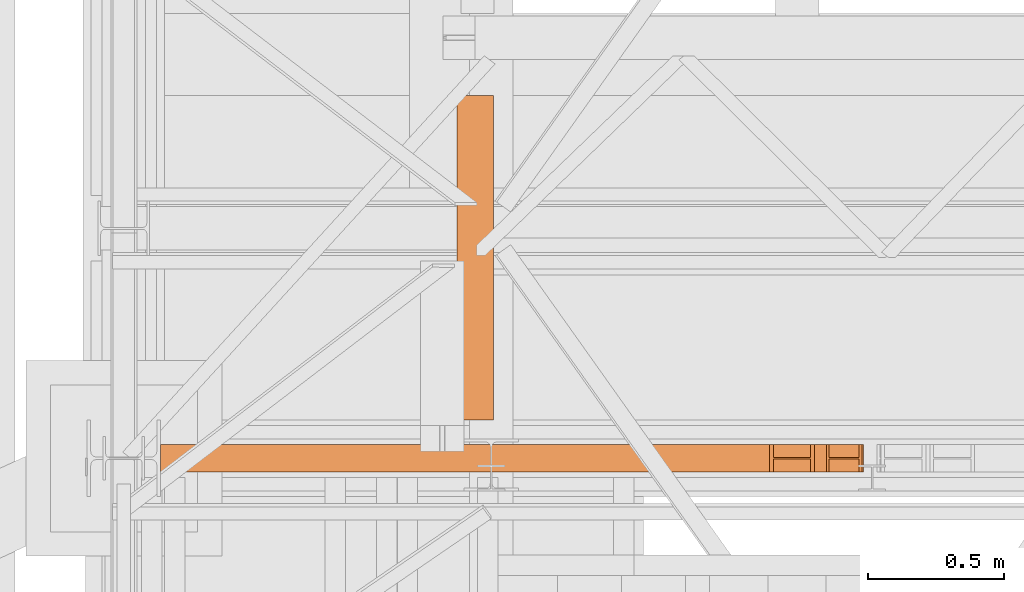
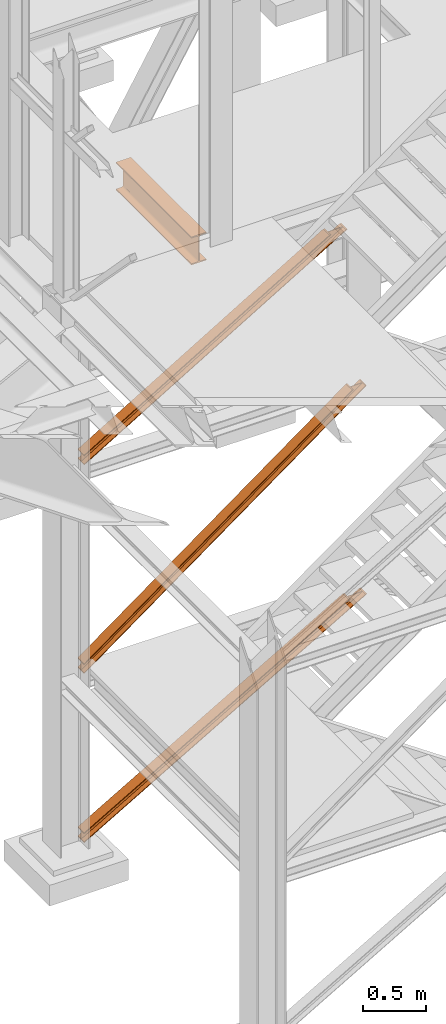
# One storey, part 15 of 208: 4 proxies.
"""IFC2X3 building model written with IfcOpenShell, lengths in millimetres."""

from ifc_helpers import new_model, entity, si_unit, converted_unit, frame, origin, origin_with_axes, place, context, subcontext, project, spatial, faceted_brep, element, save


model = new_model("IFC2X3")

# Units and contexts
model_context = context("Model", 3, precision=1e-05, world=origin())
plan_context = context("Plan", 3, precision=1e-05, world=origin())
body_context = subcontext(model_context, "Body", "Model", "MODEL_VIEW")
ifc_project = project(units=[si_unit("LENGTHUNIT", "METRE", prefix="MILLI"), converted_unit("PLANEANGLEUNIT", "DEGREE", entity("IfcPlaneAngleMeasure", 0.0174532925199433), si_unit("PLANEANGLEUNIT", "RADIAN"), dimensions=[0, 0, 0, 0, 0, 0, 0]), si_unit("AREAUNIT", "SQUARE_METRE"), si_unit("VOLUMEUNIT", "CUBIC_METRE")], contexts=[model_context, plan_context])

# Building, storey
building_placement = place(None, origin())
building = spatial("IfcBuilding", under=ifc_project, at=building_placement, CompositionType="COMPLEX")
storey_placement = place(building_placement, origin_with_axes())
storey = spatial("IfcBuildingStorey", under=building, at=storey_placement, Name="Geschoss", CompositionType="ELEMENT")

# Proxies
proxy_1_placement = place(storey_placement, frame((1333.254973893079, -22112.57439031789, 1566.490000221248), z_axis=(0.0, 0.0, 1.0), x_axis=(1.0, 0.0, 0.0)))
element("IfcBuildingElementProxy", 1, at=proxy_1_placement, inside=storey, context=body_context, shape_type="Brep", body=[
    faceted_brep([(0.009999999999990905, 0.00999999999839929, 88.00999999999999), (0.009999999999990905, 47.5099999999984, 88.00999999999999), (0.009999999999990905, 47.5099999999984, 8.009999999999991), (0.009999999999990905, 0.00999999999839929, 8.009999999999991), (0.009999999999990905, 0.00999999999839929, 0.009999999999990905), (0.009999999999990905, 100.0099999999984, 0.009999999999990905), (0.009999999999990905, 100.0099999999984, 8.009999999999991), (0.009999999999990905, 52.5099999999984, 8.009999999999991), (0.009999999999990905, 52.5099999999984, 88.00999999999999), (0.009999999999990905, 100.0099999999984, 88.00999999999999), (0.009999999999990905, 100.0099999999984, 96.00999999999999), (0.009999999999990905, 0.00999999999839929, 96.00999999999999), (0.009999999999990905, 0.00999999999839929, 96.00999999999999), (2446.533171438392, 0.01000000000567525, 1881.009998688699), (2457.497981178383, 0.01000000000567525, 1881.009998688699), (0.009999999999990905, 0.00999999999839929, 88.00999999999999), (0.009999999999990905, 100.0099999999984, 96.00999999999999), (2446.533171438393, 100.0100000000057, 1881.009998688699), (2446.533171438392, 0.01000000000567525, 1881.009998688699), (0.009999999999990905, 0.00999999999839929, 96.00999999999999), (0.009999999999990905, 100.0099999999984, 88.00999999999999), (2457.497981178383, 100.010000000002, 1881.009998688699), (2446.533171438393, 100.0100000000057, 1881.009998688699), (0.009999999999990905, 100.0099999999984, 96.00999999999999), (0.009999999999990905, 52.5099999999984, 88.00999999999999), (2457.497981178384, 52.51000000000568, 1881.0099986887), (2457.497981178383, 100.010000000002, 1881.009998688699), (0.009999999999990905, 100.0099999999984, 88.00999999999999), (0.009999999999990905, 52.5099999999984, 8.009999999999991), (2567.146078578301, 52.51000000000568, 1881.009998688699), (2457.497981178384, 52.51000000000568, 1881.0099986887), (0.009999999999990905, 52.5099999999984, 88.00999999999999), (0.009999999999990905, 100.0099999999984, 8.009999999999991), (2567.146078578302, 100.0100000000057, 1881.009998688699), (2567.146078578301, 52.51000000000568, 1881.009998688699), (0.009999999999990905, 52.5099999999984, 8.009999999999991), (0.009999999999990905, 100.0099999999984, 0.009999999999990905), (2578.110888318293, 100.0100000000057, 1881.009998688699), (2567.146078578302, 100.0100000000057, 1881.009998688699), (0.009999999999990905, 100.0099999999984, 8.009999999999991), (0.009999999999990905, 0.00999999999839929, 0.009999999999990905), (2578.110888318294, 0.01000000000567525, 1881.009998688699), (2578.110888318293, 100.0100000000057, 1881.009998688699), (0.009999999999990905, 100.0099999999984, 0.009999999999990905), (0.009999999999990905, 0.00999999999839929, 8.009999999999991), (2567.146078578301, 0.01000000000567525, 1881.009998688699), (2578.110888318294, 0.01000000000567525, 1881.009998688699), (0.009999999999990905, 0.00999999999839929, 0.009999999999990905), (0.009999999999990905, 47.5099999999984, 8.009999999999991), (2567.146078578302, 47.51000000000568, 1881.009998688699), (2567.146078578301, 0.01000000000567525, 1881.009998688699), (0.009999999999990905, 0.00999999999839929, 8.009999999999991), (0.009999999999990905, 47.5099999999984, 88.00999999999999), (2457.497981178383, 47.51000000000568, 1881.009998688699), (2567.146078578302, 47.51000000000568, 1881.009998688699), (0.009999999999990905, 47.5099999999984, 8.009999999999991), (0.009999999999990905, 0.00999999999839929, 88.00999999999999), (2457.497981178383, 0.01000000000567525, 1881.009998688699), (2457.497981178383, 47.51000000000568, 1881.009998688699), (0.009999999999990905, 47.5099999999984, 88.00999999999999), (2446.533171438392, 0.01000000000567525, 1881.009998688699), (2446.533171438393, 100.0100000000057, 1881.009998688699), (2457.497981178383, 100.010000000002, 1881.009998688699), (2457.497981178384, 52.51000000000568, 1881.0099986887), (2567.146078578301, 52.51000000000568, 1881.009998688699), (2567.146078578302, 100.0100000000057, 1881.009998688699), (2578.110888318293, 100.0100000000057, 1881.009998688699), (2578.110888318294, 0.01000000000567525, 1881.009998688699), (2567.146078578301, 0.01000000000567525, 1881.009998688699), (2567.146078578302, 47.51000000000568, 1881.009998688699), (2457.497981178383, 47.51000000000568, 1881.009998688699), (2457.497981178383, 0.01000000000567525, 1881.009998688699)], [[[0, 1, 2, 3, 4, 5, 6, 7, 8, 9, 10, 11]], [[12, 13, 14, 15]], [[16, 17, 18, 19]], [[20, 21, 22, 23]], [[24, 25, 26, 27]], [[28, 29, 30, 31]], [[32, 33, 34, 35]], [[36, 37, 38, 39]], [[40, 41, 42, 43]], [[44, 45, 46, 47]], [[48, 49, 50, 51]], [[52, 53, 54, 55]], [[56, 57, 58, 59]], [[60, 61, 62, 63, 64, 65, 66, 67, 68, 69, 70, 71]]], orient=[[False], [False], [False], [False], [False], [False], [False], [False], [False], [False], [False], [False], [False], [False]]),
])
proxy_2_placement = place(storey_placement, frame((1333.25497389308, -22112.57439031789, -65.01000000000045), z_axis=(0.0, 0.0, 1.0), x_axis=(1.0, 0.0, 0.0)))
element("IfcBuildingElementProxy", 2, at=proxy_2_placement, inside=storey, context=body_context, shape_type="Brep", body=[
    faceted_brep([(0.009999999999990905, 0.00999999999839929, 88.01000000000005), (0.009999999999990905, 47.5099999999984, 88.01000000000005), (0.009999999999990905, 47.5099999999984, 8.010000000000048), (0.009999999999990905, 0.00999999999839929, 8.010000000000048), (0.009999999999990905, 0.00999999999839929, 0.01000000000004775), (0.009999999999990905, 100.0099999999984, 0.01000000000004775), (0.009999999999990905, 100.0099999999984, 8.010000000000048), (0.009999999999990905, 52.5099999999984, 8.010000000000048), (0.009999999999990905, 52.5099999999984, 88.01000000000005), (0.009999999999990905, 100.0099999999984, 88.01000000000005), (0.009999999999990905, 100.0099999999984, 96.01000000000005), (0.009999999999990905, 0.00999999999839929, 96.01000000000005), (0.009999999999990905, 0.00999999999839929, 96.01000000000005), (2417.635238083693, 0.01000000000567525, 1498.509998909946), (2431.425613784015, 0.01000000000203727, 1498.509998909946), (0.009999999999990905, 0.00999999999839929, 88.01000000000005), (0.009999999999990905, 100.0099999999984, 96.01000000000005), (2417.635238083693, 100.010000000002, 1498.509998909947), (2417.635238083693, 0.01000000000567525, 1498.509998909946), (0.009999999999990905, 0.00999999999839929, 96.01000000000005), (0.009999999999990905, 100.0099999999984, 88.01000000000005), (2431.425613784015, 100.0100000000057, 1498.509998909946), (2417.635238083693, 100.010000000002, 1498.509998909947), (0.009999999999990905, 100.0099999999984, 96.01000000000005), (0.009999999999990905, 52.5099999999984, 88.01000000000005), (2431.425613784016, 52.51000000000204, 1498.509998909946), (2431.425613784015, 100.0100000000057, 1498.509998909946), (0.009999999999990905, 100.0099999999984, 88.01000000000005), (0.009999999999990905, 52.5099999999984, 8.010000000000048), (2569.329370787236, 52.51000000000568, 1498.509998909946), (2431.425613784016, 52.51000000000204, 1498.509998909946), (0.009999999999990905, 52.5099999999984, 88.01000000000005), (0.009999999999990905, 100.0099999999984, 8.010000000000048), (2569.329370787237, 100.010000000002, 1498.509998909947), (2569.329370787236, 52.51000000000568, 1498.509998909946), (0.009999999999990905, 52.5099999999984, 8.010000000000048), (0.009999999999990905, 100.0099999999984, 0.01000000000004775), (2583.119746487559, 100.0100000000057, 1498.509998909946), (2569.329370787237, 100.010000000002, 1498.509998909947), (0.009999999999990905, 100.0099999999984, 8.010000000000048), (0.009999999999990905, 0.00999999999839929, 0.01000000000004775), (2583.11974648756, 0.01000000000567525, 1498.509998909947), (2583.119746487559, 100.0100000000057, 1498.509998909946), (0.009999999999990905, 100.0099999999984, 0.01000000000004775), (0.009999999999990905, 0.00999999999839929, 8.010000000000048), (2569.329370787236, 0.01000000000567525, 1498.509998909946), (2583.11974648756, 0.01000000000567525, 1498.509998909947), (0.009999999999990905, 0.00999999999839929, 0.01000000000004775), (0.009999999999990905, 47.5099999999984, 8.010000000000048), (2569.329370787237, 47.51000000000568, 1498.509998909947), (2569.329370787236, 0.01000000000567525, 1498.509998909946), (0.009999999999990905, 0.00999999999839929, 8.010000000000048), (0.009999999999990905, 47.5099999999984, 88.01000000000005), (2431.425613784015, 47.51000000000568, 1498.509998909946), (2569.329370787237, 47.51000000000568, 1498.509998909947), (0.009999999999990905, 47.5099999999984, 8.010000000000048), (0.009999999999990905, 0.00999999999839929, 88.01000000000005), (2431.425613784015, 0.01000000000203727, 1498.509998909946), (2431.425613784015, 47.51000000000568, 1498.509998909946), (0.009999999999990905, 47.5099999999984, 88.01000000000005), (2417.635238083693, 0.01000000000567525, 1498.509998909946), (2417.635238083693, 100.010000000002, 1498.509998909947), (2431.425613784015, 100.0100000000057, 1498.509998909946), (2431.425613784016, 52.51000000000204, 1498.509998909946), (2569.329370787236, 52.51000000000568, 1498.509998909946), (2569.329370787237, 100.010000000002, 1498.509998909947), (2583.119746487559, 100.0100000000057, 1498.509998909946), (2583.11974648756, 0.01000000000567525, 1498.509998909947), (2569.329370787236, 0.01000000000567525, 1498.509998909946), (2569.329370787237, 47.51000000000568, 1498.509998909947), (2431.425613784015, 47.51000000000568, 1498.509998909946), (2431.425613784015, 0.01000000000203727, 1498.509998909946)], [[[0, 1, 2, 3, 4, 5, 6, 7, 8, 9, 10, 11]], [[12, 13, 14, 15]], [[16, 17, 18, 19]], [[20, 21, 22, 23]], [[24, 25, 26, 27]], [[28, 29, 30, 31]], [[32, 33, 34, 35]], [[36, 37, 38, 39]], [[40, 41, 42, 43]], [[44, 45, 46, 47]], [[48, 49, 50, 51]], [[52, 53, 54, 55]], [[56, 57, 58, 59]], [[60, 61, 62, 63, 64, 65, 66, 67, 68, 69, 70, 71]]], orient=[[False], [False], [False], [False], [False], [False], [False], [False], [False], [False], [False], [False], [False], [False]]),
])
proxy_3_placement = place(storey_placement, frame((2422.738204365546, -21922.57438972183, 5014.990005364414), z_axis=(0.0, 0.0, 1.0), x_axis=(1.0, 0.0, 0.0)))
element("IfcBuildingElementProxy", 3, at=proxy_3_placement, inside=storey, context=body_context, shape_type="Brep", body=[
    faceted_brep([(135.0100000000002, 0.00999999999839929, 270.0100000000011), (135.0100000000011, 1194.009999593942, 270.010000000002), (135.0100000000011, 1194.009999593942, 259.810000190736), (135.0100000000002, 0.00999999999839929, 259.810000190736), (135.0100000000002, 0.00999999999839929, 259.810000190736), (135.0100000000011, 1194.009999593942, 259.810000190736), (85.80999995231741, 1194.009999593942, 259.810000190736), (85.8099999523165, 0.00999999999839929, 259.810000190736), (85.8099999523165, 0.00999999999839929, 259.810000190736), (85.80999995231741, 1194.009999593942, 259.810000190736), (81.17476076017283, 1194.009999593942, 259.0757968253247), (81.17476076017192, 0.00999999999839929, 259.0757968253247), (81.17476076017192, 0.00999999999839929, 259.0757968253247), (81.17476076017283, 1194.009999593942, 259.0757968253247), (76.99323602687309, 1194.009999593942, 256.9452365592933), (76.99323602687218, 0.00999999999839929, 256.9452365592933), (76.99323602687218, 0.00999999999839929, 256.9452365592933), (76.99323602687309, 1194.009999593942, 256.9452365592933), (73.67476358376189, 1194.009999593942, 253.6267641161803), (73.67476358376007, 0.00999999999839929, 253.6267641161812), (73.67476358376007, 0.00999999999839929, 253.6267641161812), (73.67476358376189, 1194.009999593942, 253.6267641161803), (71.54420331772872, 1194.009999593942, 249.4452393828806), (71.5442033177278, 0.00999999999839929, 249.4452393828806), (71.5442033177278, 0.00999999999839929, 249.4452393828806), (71.54420331772872, 1194.009999593942, 249.4452393828806), (70.8099999523156, 1194.009999593942, 244.8100001907369), (70.8099999523165, 0.00999999999839929, 244.8100001907369), (70.8099999523165, 0.00999999999839929, 244.8100001907369), (70.8099999523156, 1194.009999593942, 244.8100001907369), (70.8099999523156, 1194.009999593942, 25.20999980926717), (70.8099999523165, 0.00999999999839929, 25.20999980926626), (70.8099999523165, 0.00999999999839929, 25.20999980926626), (70.8099999523156, 1194.009999593942, 25.20999980926717), (71.5442033177278, 1194.009999593942, 20.57476061712168), (71.5442033177278, 0.00999999999839929, 20.57476061712168), (71.5442033177278, 0.00999999999839929, 20.57476061712168), (71.5442033177278, 1194.009999593942, 20.57476061712168), (73.67476358376098, 1194.009999593942, 16.39323588382194), (73.67476358376007, 0.00999999999839929, 16.39323588382104), (73.67476358376007, 0.00999999999839929, 16.39323588382104), (73.67476358376098, 1194.009999593942, 16.39323588382194), (76.99323602687309, 1194.009999593942, 13.07476344070983), (76.99323602687218, 0.00999999999839929, 13.07476344070892), (76.99323602687218, 0.00999999999839929, 13.07476344070892), (76.99323602687309, 1194.009999593942, 13.07476344070983), (81.17476076017283, 1194.009999593942, 10.94420317467848), (81.17476076017192, 0.00999999999839929, 10.94420317467757), (81.17476076017192, 0.00999999999839929, 10.94420317467757), (81.17476076017283, 1194.009999593942, 10.94420317467848), (85.80999995231741, 1194.009999593942, 10.20999980926626), (85.8099999523165, 0.00999999999839929, 10.20999980926626), (85.8099999523165, 0.00999999999839929, 10.20999980926626), (85.80999995231741, 1194.009999593942, 10.20999980926626), (135.0100000000011, 1194.009999593942, 10.20999980926626), (135.0100000000002, 0.00999999999839929, 10.20999980926626), (135.0100000000002, 0.00999999999839929, 10.20999980926626), (135.0100000000011, 1194.009999593942, 10.20999980926626), (135.0100000000011, 1194.009999593942, 0.01000000000021828), (135.0100000000002, 0.00999999999839929, 0.01000000000203727), (135.0100000000002, 0.00999999999839929, 0.01000000000203727), (135.0100000000011, 1194.009999593942, 0.01000000000021828), (0.01000000000112777, 1194.009999593942, 0.01000000000203727), (0.01000000000021828, 0.00999999999839929, 0.01000000000203727), (0.01000000000021828, 0.00999999999839929, 0.01000000000203727), (0.01000000000112777, 1194.009999593942, 0.01000000000203727), (0.01000000000112777, 1194.009999593942, 10.20999980926717), (0.01000000000021828, 0.00999999999839929, 10.20999980926626), (0.01000000000021828, 0.00999999999839929, 10.20999980926626), (0.01000000000112777, 1194.009999593942, 10.20999980926717), (49.21000004768484, 1194.009999593942, 10.20999980926626), (49.21000004768393, 0.00999999999839929, 10.20999980926626), (49.21000004768393, 0.00999999999839929, 10.20999980926626), (49.21000004768484, 1194.009999593942, 10.20999980926626), (53.09227270367228, 1194.009999593942, 10.72115637176285), (53.09227270367137, 0.00999999999839929, 10.72115637176285), (53.09227270367137, 0.00999999999839929, 10.72115637176285), (53.09227270367228, 1194.009999593942, 10.72115637176285), (56.70997817243097, 1194.009999593942, 12.21965904159333), (56.70997817243006, 0.00999999999839929, 12.21965904159333), (56.70997817243006, 0.00999999999839929, 12.21965904159333), (56.70997817243097, 1194.009999593942, 12.21965904159333), (59.81660176548303, 1194.009999593942, 14.60339809146808), (59.81660176548212, 0.00999999999839929, 14.60339809146808), (59.81660176548212, 0.00999999999839929, 14.60339809146808), (59.81660176548303, 1194.009999593942, 14.60339809146808), (62.20034081535687, 1194.009999593942, 17.71002168452105), (62.20034081535687, 0.00999999999839929, 17.71002168452105), (62.20034081535687, 0.00999999999839929, 17.71002168452105), (62.20034081535687, 1194.009999593942, 17.71002168452105), (63.69884348518917, 1194.009999593942, 21.32772715327883), (63.69884348518826, 0.00999999999839929, 21.32772715327883), (63.69884348518826, 0.00999999999839929, 21.32772715327883), (63.69884348518917, 1194.009999593942, 21.32772715327883), (64.21000004768484, 1194.009999593942, 25.20999980926626), (64.21000004768393, 0.00999999999839929, 25.20999980926626), (64.21000004768393, 0.00999999999839929, 25.20999980926626), (64.21000004768484, 1194.009999593942, 25.20999980926626), (64.21000004768484, 1194.009999593942, 244.810000190736), (64.21000004768393, 0.00999999999839929, 244.810000190736), (64.21000004768393, 0.00999999999839929, 244.810000190736), (64.21000004768484, 1194.009999593942, 244.810000190736), (63.47579668227354, 1194.009999593942, 249.4452393828797), (63.47579668227263, 0.00999999999839929, 249.4452393828797), (63.47579668227263, 0.00999999999839929, 249.4452393828797), (63.47579668227354, 1194.009999593942, 249.4452393828797), (61.34523641624219, 1194.009999593942, 253.6267641161812), (61.34523641624128, 0.00999999999839929, 253.6267641161812), (61.34523641624128, 0.00999999999839929, 253.6267641161812), (61.34523641624219, 1194.009999593942, 253.6267641161812), (58.02676397313098, 1194.009999593942, 256.9452365592933), (58.02676397313007, 0.00999999999839929, 256.9452365592933), (58.02676397313007, 0.00999999999839929, 256.9452365592933), (58.02676397313098, 1194.009999593942, 256.9452365592933), (53.84523923982943, 1194.009999593942, 259.0757968253247), (53.84523923982852, 0.00999999999839929, 259.0757968253247), (53.84523923982852, 0.00999999999839929, 259.0757968253247), (53.84523923982943, 1194.009999593942, 259.0757968253247), (49.21000004768484, 1194.009999593942, 259.8100001907369), (49.21000004768393, 0.00999999999839929, 259.810000190736), (49.21000004768393, 0.00999999999839929, 259.810000190736), (49.21000004768484, 1194.009999593942, 259.8100001907369), (0.01000000000112777, 1194.009999593942, 259.810000190736), (0.01000000000021828, 0.00999999999839929, 259.810000190736), (0.01000000000021828, 0.00999999999839929, 259.810000190736), (0.01000000000112777, 1194.009999593942, 259.810000190736), (0.01000000000112777, 1194.009999593942, 270.0100000000002), (0.01000000000021828, 0.00999999999839929, 270.0100000000011), (0.01000000000021828, 0.00999999999839929, 270.0100000000011), (0.01000000000112777, 1194.009999593942, 270.0100000000002), (135.0100000000011, 1194.009999593942, 270.010000000002), (135.0100000000002, 0.00999999999839929, 270.0100000000011), (135.0100000000002, 0.00999999999839929, 270.0100000000011), (135.0100000000002, 0.00999999999839929, 259.810000190736), (85.8099999523165, 0.00999999999839929, 259.810000190736), (81.17476076017192, 0.00999999999839929, 259.0757968253247), (76.99323602687218, 0.00999999999839929, 256.9452365592933), (73.67476358376007, 0.00999999999839929, 253.6267641161812), (71.5442033177278, 0.00999999999839929, 249.4452393828806), (70.8099999523165, 0.00999999999839929, 244.8100001907369), (70.8099999523165, 0.00999999999839929, 25.20999980926626), (71.5442033177278, 0.00999999999839929, 20.57476061712168), (73.67476358376007, 0.00999999999839929, 16.39323588382104), (76.99323602687218, 0.00999999999839929, 13.07476344070892), (81.17476076017192, 0.00999999999839929, 10.94420317467757), (85.8099999523165, 0.00999999999839929, 10.20999980926626), (135.0100000000002, 0.00999999999839929, 10.20999980926626), (135.0100000000002, 0.00999999999839929, 0.01000000000203727), (0.01000000000021828, 0.00999999999839929, 0.01000000000203727), (0.01000000000021828, 0.00999999999839929, 10.20999980926626), (49.21000004768393, 0.00999999999839929, 10.20999980926626), (53.09227270367137, 0.00999999999839929, 10.72115637176285), (56.70997817243006, 0.00999999999839929, 12.21965904159333), (59.81660176548212, 0.00999999999839929, 14.60339809146808), (62.20034081535687, 0.00999999999839929, 17.71002168452105), (63.69884348518826, 0.00999999999839929, 21.32772715327883), (64.21000004768393, 0.00999999999839929, 25.20999980926626), (64.21000004768393, 0.00999999999839929, 244.810000190736), (63.47579668227263, 0.00999999999839929, 249.4452393828797), (61.34523641624128, 0.00999999999839929, 253.6267641161812), (58.02676397313007, 0.00999999999839929, 256.9452365592933), (53.84523923982852, 0.00999999999839929, 259.0757968253247), (49.21000004768393, 0.00999999999839929, 259.810000190736), (0.01000000000021828, 0.00999999999839929, 259.810000190736), (0.01000000000021828, 0.00999999999839929, 270.0100000000011), (73.67476358376189, 1194.009999593942, 253.6267641161803), (76.99323602687309, 1194.009999593942, 256.9452365592933), (81.17476076017283, 1194.009999593942, 259.0757968253247), (85.80999995231741, 1194.009999593942, 259.810000190736), (135.0100000000011, 1194.009999593942, 259.810000190736), (135.0100000000011, 1194.009999593942, 270.010000000002), (0.01000000000112777, 1194.009999593942, 270.0100000000002), (0.01000000000112777, 1194.009999593942, 259.810000190736), (49.21000004768484, 1194.009999593942, 259.8100001907369), (53.84523923982943, 1194.009999593942, 259.0757968253247), (58.02676397313098, 1194.009999593942, 256.9452365592933), (61.34523641624219, 1194.009999593942, 253.6267641161812), (63.47579668227354, 1194.009999593942, 249.4452393828797), (64.21000004768484, 1194.009999593942, 244.810000190736), (64.21000004768484, 1194.009999593942, 25.20999980926626), (63.69884348518917, 1194.009999593942, 21.32772715327883), (62.20034081535687, 1194.009999593942, 17.71002168452105), (59.81660176548303, 1194.009999593942, 14.60339809146808), (56.70997817243097, 1194.009999593942, 12.21965904159333), (53.09227270367228, 1194.009999593942, 10.72115637176285), (49.21000004768484, 1194.009999593942, 10.20999980926626), (0.01000000000112777, 1194.009999593942, 10.20999980926717), (0.01000000000112777, 1194.009999593942, 0.01000000000203727), (135.0100000000011, 1194.009999593942, 0.01000000000021828), (135.0100000000011, 1194.009999593942, 10.20999980926626), (85.80999995231741, 1194.009999593942, 10.20999980926626), (81.17476076017283, 1194.009999593942, 10.94420317467848), (76.99323602687309, 1194.009999593942, 13.07476344070983), (73.67476358376098, 1194.009999593942, 16.39323588382194), (71.5442033177278, 1194.009999593942, 20.57476061712168), (70.8099999523156, 1194.009999593942, 25.20999980926717), (70.8099999523156, 1194.009999593942, 244.8100001907369), (71.54420331772872, 1194.009999593942, 249.4452393828806)], [[[0, 1, 2, 3]], [[4, 5, 6, 7]], [[8, 9, 10, 11]], [[12, 13, 14, 15]], [[16, 17, 18, 19]], [[20, 21, 22, 23]], [[24, 25, 26, 27]], [[28, 29, 30, 31]], [[32, 33, 34, 35]], [[36, 37, 38, 39]], [[40, 41, 42, 43]], [[44, 45, 46, 47]], [[48, 49, 50, 51]], [[52, 53, 54, 55]], [[56, 57, 58, 59]], [[60, 61, 62, 63]], [[64, 65, 66, 67]], [[68, 69, 70, 71]], [[72, 73, 74, 75]], [[76, 77, 78, 79]], [[80, 81, 82, 83]], [[84, 85, 86, 87]], [[88, 89, 90, 91]], [[92, 93, 94, 95]], [[96, 97, 98, 99]], [[100, 101, 102, 103]], [[104, 105, 106, 107]], [[108, 109, 110, 111]], [[112, 113, 114, 115]], [[116, 117, 118, 119]], [[120, 121, 122, 123]], [[124, 125, 126, 127]], [[128, 129, 130, 131]], [[132, 133, 134, 135, 136, 137, 138, 139, 140, 141, 142, 143, 144, 145, 146, 147, 148, 149, 150, 151, 152, 153, 154, 155, 156, 157, 158, 159, 160, 161, 162, 163, 164]], [[165, 166, 167, 168, 169, 170, 171, 172, 173, 174, 175, 176, 177, 178, 179, 180, 181, 182, 183, 184, 185, 186, 187, 188, 189, 190, 191, 192, 193, 194, 195, 196, 197]]], orient=[[False], [False], [False], [False], [False], [False], [False], [False], [False], [False], [False], [False], [False], [False], [False], [False], [False], [False], [False], [False], [False], [False], [False], [False], [False], [False], [False], [False], [False], [False], [False], [False], [False], [False], [False]]),
])
proxy_4_placement = place(storey_placement, frame((1333.254973893077, -22112.57439031789, 3580.490000221249), z_axis=(0.0, 0.0, 1.0), x_axis=(1.0, 0.0, 0.0)))
element("IfcBuildingElementProxy", 4, at=proxy_4_placement, inside=storey, context=body_context, shape_type="Brep", body=[
    faceted_brep([(0.009999999999990905, 0.01000000000203727, 88.01000000000022), (0.009999999999990905, 47.51000000000204, 88.01000000000022), (0.009999999999990905, 47.51000000000204, 8.010000000000218), (0.009999999999990905, 0.01000000000203727, 8.010000000000218), (0.009999999999990905, 0.01000000000203727, 0.01000000000021828), (0.009999999999990905, 100.010000000002, 0.01000000000021828), (0.009999999999990905, 100.010000000002, 8.010000000000218), (0.009999999999990905, 52.51000000000204, 8.010000000000218), (0.009999999999990905, 52.51000000000204, 88.01000000000022), (0.009999999999990905, 100.010000000002, 88.01000000000022), (0.009999999999990905, 100.010000000002, 96.01000000000022), (0.009999999999990905, 0.01000000000203727, 96.01000000000022), (0.009999999999990905, 0.01000000000203727, 96.01000000000022), (2238.627931874558, 0.01000000000567525, 1434.509994414332), (2252.314552726377, 0.01000000000567525, 1434.509994414332), (0.009999999999990905, 0.01000000000203727, 88.01000000000022), (0.009999999999990905, 100.010000000002, 96.01000000000022), (2238.627931874558, 100.0100000000057, 1434.509994414332), (2238.627931874558, 0.01000000000567525, 1434.509994414332), (0.009999999999990905, 0.01000000000203727, 96.01000000000022), (0.009999999999990905, 100.010000000002, 88.01000000000022), (2252.314552726377, 100.0100000000057, 1434.509994414332), (2238.627931874558, 100.0100000000057, 1434.509994414332), (0.009999999999990905, 100.010000000002, 96.01000000000022), (0.009999999999990905, 52.51000000000204, 88.01000000000022), (2252.314552726377, 52.51000000000568, 1434.509994414332), (2252.314552726377, 100.0100000000057, 1434.509994414332), (0.009999999999990905, 100.010000000002, 88.01000000000022), (0.009999999999990905, 52.51000000000204, 8.010000000000218), (2389.180761244557, 52.51000000000568, 1434.509994414332), (2252.314552726377, 52.51000000000568, 1434.509994414332), (0.009999999999990905, 52.51000000000204, 88.01000000000022), (0.009999999999990905, 100.010000000002, 8.010000000000218), (2389.180761244556, 100.0100000000057, 1434.509994414333), (2389.180761244557, 52.51000000000568, 1434.509994414332), (0.009999999999990905, 52.51000000000204, 8.010000000000218), (0.009999999999990905, 100.010000000002, 0.01000000000021828), (2402.867382096375, 100.0100000000057, 1434.509994414332), (2389.180761244556, 100.0100000000057, 1434.509994414333), (0.009999999999990905, 100.010000000002, 8.010000000000218), (0.009999999999990905, 0.01000000000203727, 0.01000000000021828), (2402.867382096375, 0.01000000000567525, 1434.509994414332), (2402.867382096375, 100.0100000000057, 1434.509994414332), (0.009999999999990905, 100.010000000002, 0.01000000000021828), (0.009999999999990905, 0.01000000000203727, 8.010000000000218), (2389.180761244557, 0.01000000000567525, 1434.509994414332), (2402.867382096375, 0.01000000000567525, 1434.509994414332), (0.009999999999990905, 0.01000000000203727, 0.01000000000021828), (0.009999999999990905, 47.51000000000204, 8.010000000000218), (2389.180761244556, 47.51000000000568, 1434.509994414333), (2389.180761244557, 0.01000000000567525, 1434.509994414332), (0.009999999999990905, 0.01000000000203727, 8.010000000000218), (0.009999999999990905, 47.51000000000204, 88.01000000000022), (2252.314552726377, 47.51000000000568, 1434.509994414332), (2389.180761244556, 47.51000000000568, 1434.509994414333), (0.009999999999990905, 47.51000000000204, 8.010000000000218), (0.009999999999990905, 0.01000000000203727, 88.01000000000022), (2252.314552726377, 0.01000000000567525, 1434.509994414332), (2252.314552726377, 47.51000000000568, 1434.509994414332), (0.009999999999990905, 47.51000000000204, 88.01000000000022), (2238.627931874558, 0.01000000000567525, 1434.509994414332), (2238.627931874558, 100.0100000000057, 1434.509994414332), (2252.314552726377, 100.0100000000057, 1434.509994414332), (2252.314552726377, 52.51000000000568, 1434.509994414332), (2389.180761244557, 52.51000000000568, 1434.509994414332), (2389.180761244556, 100.0100000000057, 1434.509994414333), (2402.867382096375, 100.0100000000057, 1434.509994414332), (2402.867382096375, 0.01000000000567525, 1434.509994414332), (2389.180761244557, 0.01000000000567525, 1434.509994414332), (2389.180761244556, 47.51000000000568, 1434.509994414333), (2252.314552726377, 47.51000000000568, 1434.509994414332), (2252.314552726377, 0.01000000000567525, 1434.509994414332)], [[[0, 1, 2, 3, 4, 5, 6, 7, 8, 9, 10, 11]], [[12, 13, 14, 15]], [[16, 17, 18, 19]], [[20, 21, 22, 23]], [[24, 25, 26, 27]], [[28, 29, 30, 31]], [[32, 33, 34, 35]], [[36, 37, 38, 39]], [[40, 41, 42, 43]], [[44, 45, 46, 47]], [[48, 49, 50, 51]], [[52, 53, 54, 55]], [[56, 57, 58, 59]], [[60, 61, 62, 63, 64, 65, 66, 67, 68, 69, 70, 71]]], orient=[[False], [False], [False], [False], [False], [False], [False], [False], [False], [False], [False], [False], [False], [False]]),
])

save(model, "model.ifc")
